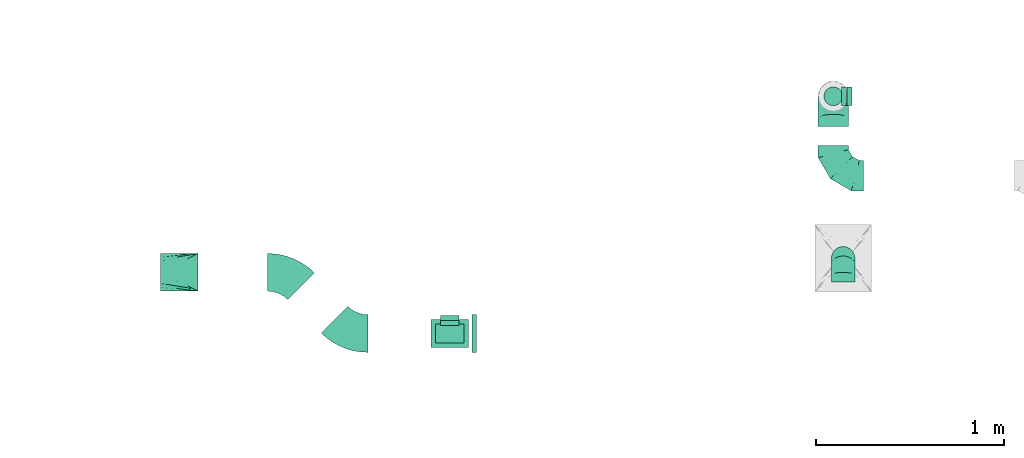
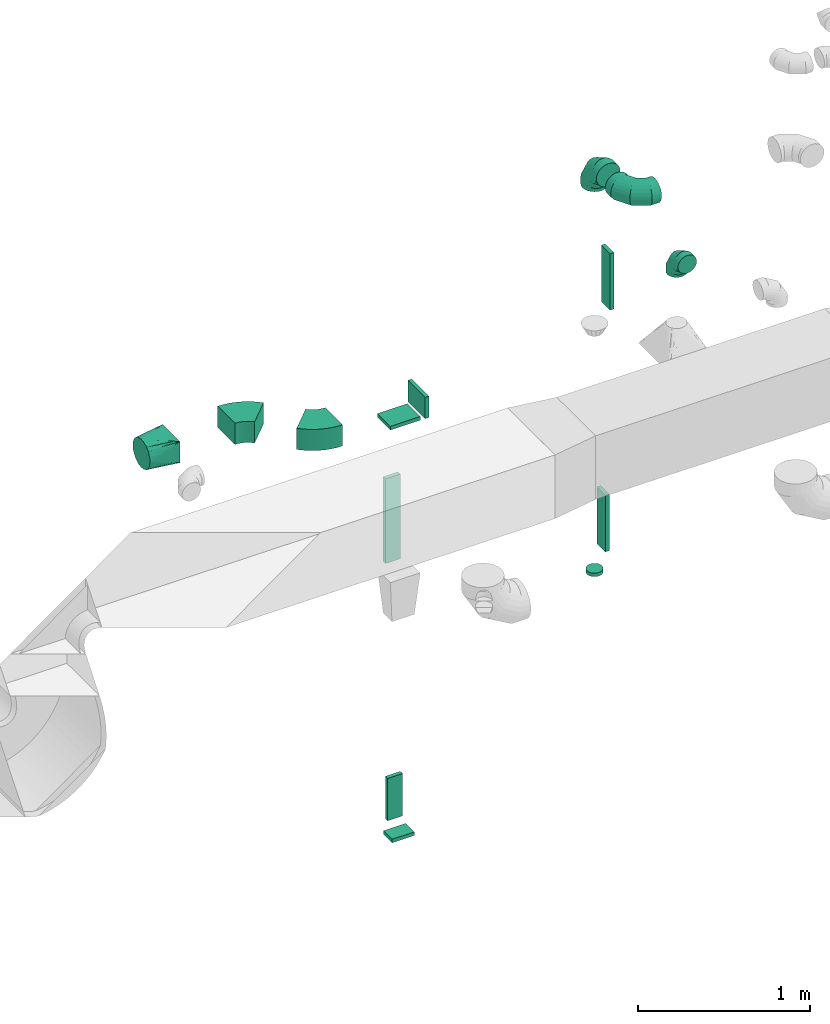
# One storey, part 78 of 97: 14 flow fittings.
"""IFC2X3 building model written with IfcOpenShell, lengths in millimetres."""

import ifcopenshell
import ifcopenshell.guid

model = None  # the IFC model being written
_history = None  # IfcOwnerHistory: only IFC2X3 demands one
_inside = {}  # id of a spatial element -> (the spatial element, [elements in it])
_under = {}  # id of a project, library or spatial element -> (it, [spatial elements below it])
_declared = {}  # id of a project -> (the project, [libraries it declares])
_typed = {}  # id of a type object -> (the type object, [elements of that type])
_made_of = {}  # id of a material, layer set ... -> (it, [elements and type objects made of it])


def new_model(schema):
    """Start an empty IFC model of exactly this schema.

    Asked for "IFC4X3", IfcOpenShell would pick the latest addendum, in which some entities
    have other attributes; the version numbers below select the first issue.
    IFC2X3 requires an IfcOwnerHistory on every rooted entity: one is made here for all.
    """
    global model, _history
    if schema == "IFC4X3":
        model = ifcopenshell.file(schema_version=(4, 3, 0, 0))
    else:
        model = ifcopenshell.file(schema=schema)
    _inside.clear()
    _under.clear()
    _declared.clear()
    _typed.clear()
    _made_of.clear()
    _history = None
    if model.schema == "IFC2X3":
        org = make("IfcOrganization", Name="unknown")
        user = make(
            "IfcPersonAndOrganization",
            ThePerson=make("IfcPerson", FamilyName="unknown"),
            TheOrganization=org,
        )
        app = make(
            "IfcApplication",
            ApplicationDeveloper=org,
            Version="unknown",
            ApplicationFullName="unknown",
            ApplicationIdentifier="unknown",
        )
        _history = make(
            "IfcOwnerHistory",
            OwningUser=user,
            OwningApplication=app,
            ChangeAction="ADDED",
            CreationDate=0,
        )
    return model


def make(cls, **values):
    """One entity of the class cls with the attributes given. An attribute that is None is left unset."""
    return model.create_entity(
        cls, **{name: value for name, value in values.items() if value is not None}
    )


def entity(cls, *values):
    """Any entity or typed value of the class cls, its attributes in the order of the schema. None: left unset."""
    e = model.create_entity(cls)
    for i, value in enumerate(values):
        if value is not None:
            e[i] = value
    return e


def rooted(cls, **values):
    """An entity with a GlobalId (a new one), such as an element, a storey or a relation."""
    return make(cls, GlobalId=ifcopenshell.guid.new(), OwnerHistory=_history, **values)


def si_unit(unit_type, name, prefix=None):
    """IfcSIUnit, for example si_unit("LENGTHUNIT", "METRE", prefix="MILLI")."""
    return make("IfcSIUnit", UnitType=unit_type, Prefix=prefix, Name=name)


def converted_unit(unit_type, name, factor, base, dimensions=None, offset=None):
    """IfcConversionBasedUnit, such as the inch: factor (a typed value) times the base unit."""
    return make(
        "IfcConversionBasedUnit"
        if offset is None
        else "IfcConversionBasedUnitWithOffset",
        ConversionOffset=offset,
        Dimensions=None
        if dimensions is None
        else entity("IfcDimensionalExponents", *dimensions),
        UnitType=unit_type,
        Name=name,
        ConversionFactor=make(
            "IfcMeasureWithUnit", ValueComponent=factor, UnitComponent=base
        ),
    )


def derived_unit(unit_type, elements):
    """IfcDerivedUnit: a product of units, each with its exponent."""
    return make(
        "IfcDerivedUnit",
        Elements=[
            make("IfcDerivedUnitElement", Unit=unit, Exponent=power)
            for unit, power in elements
        ],
        UnitType=unit_type,
    )


def assignment(units):
    """IfcUnitAssignment: the units of a project."""
    return None if units is None else make("IfcUnitAssignment", Units=units)


def point(xyz):
    """IfcCartesianPoint."""
    return None if xyz is None else make("IfcCartesianPoint", Coordinates=xyz)


def direction(xyz):
    """IfcDirection."""
    return None if xyz is None else make("IfcDirection", DirectionRatios=xyz)


def frame(location, z_axis=None, x_axis=None):
    """IfcAxis2Placement3D, a coordinate frame: its origin and axes. An axis left out is left unset."""
    return make(
        "IfcAxis2Placement3D",
        Location=point(location),
        Axis=direction(z_axis),
        RefDirection=direction(x_axis),
    )


def frame_2d(location, x_axis=None):
    """IfcAxis2Placement2D, a coordinate frame in the plane: its origin and x axis."""
    return make(
        "IfcAxis2Placement2D", Location=point(location), RefDirection=direction(x_axis)
    )


def origin():
    """The frame at (0, 0, 0) with its axes left unset."""
    return frame((0.0, 0.0, 0.0))


def origin_2d_with_axis():
    """The frame at (0, 0) in the plane with the x axis (1, 0) written out."""
    return frame_2d((0.0, 0.0), x_axis=(1.0, 0.0))


def place(relative_to, where):
    """IfcLocalPlacement: puts the frame where relative to a parent placement (None: the world)."""
    return make(
        "IfcLocalPlacement", PlacementRelTo=relative_to, RelativePlacement=where
    )


def context(
    kind, dimensions, precision=None, world=None, true_north=None, identifier=None
):
    """IfcGeometricRepresentationContext, for example the 3D "Model" context."""
    return make(
        "IfcGeometricRepresentationContext",
        ContextIdentifier=identifier,
        ContextType=kind,
        CoordinateSpaceDimension=dimensions,
        Precision=precision,
        WorldCoordinateSystem=world,
        TrueNorth=true_north,
    )


def subcontext(parent, identifier, kind, view, scale=None):
    """IfcGeometricRepresentationSubContext, for example "Body" below "Model"."""
    return make(
        "IfcGeometricRepresentationSubContext",
        ContextIdentifier=identifier,
        ContextType=kind,
        ParentContext=parent,
        TargetScale=scale,
        TargetView=view,
    )


def project(units=None, contexts=None):
    """IfcProject with its units and contexts."""
    return rooted(
        "IfcProject",
        Name="project",
        RepresentationContexts=contexts,
        UnitsInContext=assignment(units),
    )


def spatial(cls, under=None, at=None, **own):
    """A site, building, storey or space (cls), placed at a placement, below another one or the project."""
    s = rooted(cls, ObjectPlacement=at, **own)
    if under is not None:
        _under.setdefault(under.id(), (under, []))[1].append(s)
    return s


def polyline(points):
    """IfcPolyline through the points."""
    return make("IfcPolyline", Points=[point(p) for p in points])


def circle_curve(where, radius):
    """IfcCircle in the frame where."""
    return make("IfcCircle", Position=where, Radius=radius)


def parameter(value):
    """IfcParameterValue: where a trimmed curve begins or ends, as a parameter of its basis curve."""
    return model.create_entity("IfcParameterValue", value)


def trimmed(basis, trim1, trim2, sense, master):
    """IfcTrimmedCurve: the piece of a basis curve between two trims."""
    return make(
        "IfcTrimmedCurve",
        BasisCurve=basis,
        Trim1=trim1,
        Trim2=trim2,
        SenseAgreement=sense,
        MasterRepresentation=master,
    )


def segment(curve, same_sense, transition):
    """IfcCompositeCurveSegment."""
    return make(
        "IfcCompositeCurveSegment",
        Transition=transition,
        SameSense=same_sense,
        ParentCurve=curve,
    )


def composite_curve(segments, self_intersect=None):
    """IfcCompositeCurve: segments joined end to end."""
    return make("IfcCompositeCurve", Segments=segments, SelfIntersect=self_intersect)


def profile(cls, at=None, kind="AREA", **sizes):
    """A parametric profile (cls). Its sizes go by their IFC names, for example OverallWidth=200.0."""
    return make(cls, ProfileType=kind, Position=at, **sizes)


def rectangle(**sizes):
    """IfcRectangleProfileDef."""
    return profile("IfcRectangleProfileDef", **sizes)


def circle(**sizes):
    """IfcCircleProfileDef."""
    return profile("IfcCircleProfileDef", **sizes)


def outline(outer, holes=None, kind="AREA"):
    """IfcArbitraryClosedProfileDef: a profile drawn as a closed curve; with holes, ...WithVoids."""
    if holes is None:
        return make("IfcArbitraryClosedProfileDef", ProfileType=kind, OuterCurve=outer)
    return make(
        "IfcArbitraryProfileDefWithVoids",
        ProfileType=kind,
        OuterCurve=outer,
        InnerCurves=holes,
    )


def extrude(swept, where, along, depth):
    """IfcExtrudedAreaSolid: the profile swept, set in the frame where, extruded along a direction by depth."""
    return make(
        "IfcExtrudedAreaSolid",
        SweptArea=swept,
        Position=where,
        ExtrudedDirection=direction(along),
        Depth=depth,
    )


def faces_of(points, faces, orient=None, outer=None):
    """IfcFace entities. A face is a list of loops; a loop is a list of indices into points, from 0.

    orient and outer hold one flag for each loop. By default every Orientation is true, the
    first loop of a face is its IfcFaceOuterBound and the others are IfcFaceBound.
    """
    made = []
    for i, loops in enumerate(faces):
        bounds = []
        for j, loop in enumerate(loops):
            is_outer = j == 0 if outer is None else outer[i][j]
            bounds.append(
                make(
                    "IfcFaceOuterBound" if is_outer else "IfcFaceBound",
                    Bound=make("IfcPolyLoop", Polygon=[points[k] for k in loop]),
                    Orientation=True if orient is None else orient[i][j],
                )
            )
        made.append(make("IfcFace", Bounds=bounds))
    return made


def faceted_brep(points, faces, orient=None, outer=None, voids=None):
    """IfcFacetedBrep: a solid bounded by flat faces; with voids (closed shells), ...WithVoids."""
    shared = [point(p) for p in points]
    hull = make("IfcClosedShell", CfsFaces=faces_of(shared, faces, orient, outer))
    if voids is None:
        return make("IfcFacetedBrep", Outer=hull)
    return make(
        "IfcFacetedBrepWithVoids",
        Outer=hull,
        Voids=[
            make(cls, CfsFaces=faces_of(shared, fs, o, b)) for cls, fs, o, b in voids
        ],
    )


def shape(context_of_items, identifier, shape_type, items):
    """IfcShapeRepresentation: the items that make up one representation, for example the "Body"."""
    return make(
        "IfcShapeRepresentation",
        ContextOfItems=context_of_items,
        RepresentationIdentifier=identifier,
        RepresentationType=shape_type,
        Items=items,
    )


def source(mapping_origin, context_of_items, identifier, shape_type, items):
    """IfcRepresentationMap: a shape defined once, which mapped items show again and again."""
    return make(
        "IfcRepresentationMap",
        MappingOrigin=mapping_origin,
        MappedRepresentation=shape(context_of_items, identifier, shape_type, items),
    )


def transform(
    local_origin,
    x_axis=None,
    y_axis=None,
    z_axis=None,
    scale=None,
    scale2=None,
    scale3=None,
    uniform=True,
):
    """IfcCartesianTransformationOperator3D, or its non-uniform kind. x_axis, y_axis, z_axis: its Axis1, 2, 3."""
    if uniform:
        return make(
            "IfcCartesianTransformationOperator3D",
            Axis1=direction(x_axis),
            Axis2=direction(y_axis),
            LocalOrigin=point(local_origin),
            Scale=scale,
            Axis3=direction(z_axis),
        )
    return make(
        "IfcCartesianTransformationOperator3DnonUniform",
        Axis1=direction(x_axis),
        Axis2=direction(y_axis),
        LocalOrigin=point(local_origin),
        Scale=scale,
        Axis3=direction(z_axis),
        Scale2=scale2,
        Scale3=scale3,
    )


def mapped(mapping_source, mapping_target):
    """IfcMappedItem: shows the shape of a source again, moved by a transform."""
    return make(
        "IfcMappedItem", MappingSource=mapping_source, MappingTarget=mapping_target
    )


def material(Name=None, Category=None):
    """IfcMaterial."""
    return make("IfcMaterial", Name=Name, Category=Category)


def made_of(thing, what):
    """Note that an element or type object is made of a material, layer set ...; save() writes the relation."""
    if what is not None:
        _made_of.setdefault(what.id(), (what, []))[1].append(thing)
    return thing


def type_object(cls, material=None, **own):
    """A type object (cls), such as IfcWallType, which elements share."""
    return made_of(rooted(cls, **own), material)


def type_shapes(of_type, sources):
    """Give a type object the sources (RepresentationMaps) that its elements show as mapped items."""
    of_type.RepresentationMaps = sources


def element(
    cls,
    number,
    at=None,
    inside=None,
    cuts=None,
    type_object=None,
    material=None,
    context=None,
    identifier="Body",
    shape_type=None,
    held_by="IfcProductDefinitionShape",
    body=None,
    shapes=None,
    **own,
):
    """One element of the class cls, such as IfcWall. Its Tag is "e" and its number.

    at: its placement. inside: the storey or other place that contains it. cuts: it is an
    opening in that element (IfcRelVoidsElement). A single representation is given by context,
    identifier, shape_type and body (its items); several are given by shapes. held_by: the class
    of the entity that holds the representations. save() writes the other relations.
    """
    e = rooted(cls, Tag="e%d" % number, ObjectPlacement=at, **own)
    if body is not None:
        shapes = [shape(context, identifier, shape_type, body)]
    if shapes is not None:
        e.Representation = make(held_by, Representations=shapes)
    if inside is not None:
        _inside.setdefault(inside.id(), (inside, []))[1].append(e)
    if cuts is not None:
        rooted(
            "IfcRelVoidsElement", RelatingBuildingElement=cuts, RelatedOpeningElement=e
        )
    if type_object is not None:
        _typed.setdefault(type_object.id(), (type_object, []))[1].append(e)
    return made_of(e, material)


def aggregate(whole, parts):
    """IfcRelAggregates: a whole, such as a stair, and the parts it consists of."""
    return rooted("IfcRelAggregates", RelatingObject=whole, RelatedObjects=parts)


def save(model, path):
    """Write the relations noted so far, then the file.

    IfcRelAggregates (storeys below a building ...), IfcRelContainedInSpatialStructure (elements
    in a storey), IfcRelDefinesByType, IfcRelAssociatesMaterial and IfcRelDeclares: one each for
    every whole, place, type object, material and project.
    """
    for whole, parts in _under.values():
        aggregate(whole, parts)
    for where, things in _inside.values():
        rooted(
            "IfcRelContainedInSpatialStructure",
            RelatedElements=things,
            RelatingStructure=where,
        )
    for kind, things in _typed.values():
        rooted("IfcRelDefinesByType", RelatedObjects=things, RelatingType=kind)
    for what, things in _made_of.values():
        rooted("IfcRelAssociatesMaterial", RelatedObjects=things, RelatingMaterial=what)
    for by, libraries in _declared.values():
        rooted("IfcRelDeclares", RelatingContext=by, RelatedDefinitions=libraries)
    model.write(path)


model = new_model("IFC2X3")

# Units and contexts
model_context = context("Model", 3, precision=0.01, world=origin(), true_north=direction((6.12303176911189e-17, 1.0)))
body_context = subcontext(model_context, "Body", "Model", "MODEL_VIEW")
ifc_project = project(units=[si_unit("LENGTHUNIT", "METRE", prefix="MILLI"), si_unit("AREAUNIT", "SQUARE_METRE"), si_unit("VOLUMEUNIT", "CUBIC_METRE"), converted_unit("PLANEANGLEUNIT", "DEGREE", entity("IfcRatioMeasure", 0.0174532925199433), si_unit("PLANEANGLEUNIT", "RADIAN"), dimensions=[0, 0, 0, 0, 0, 0, 0]), si_unit("MASSUNIT", "GRAM", prefix="KILO"), derived_unit("MASSDENSITYUNIT", [(si_unit("MASSUNIT", "GRAM", prefix="KILO"), 1), (si_unit("LENGTHUNIT", "METRE"), -3)]), derived_unit("MOMENTOFINERTIAUNIT", [(si_unit("LENGTHUNIT", "METRE"), 4)]), si_unit("TIMEUNIT", "SECOND"), si_unit("FREQUENCYUNIT", "HERTZ"), si_unit("THERMODYNAMICTEMPERATUREUNIT", "DEGREE_CELSIUS"), derived_unit("THERMALTRANSMITTANCEUNIT", [(si_unit("MASSUNIT", "GRAM", prefix="KILO"), 1), (si_unit("THERMODYNAMICTEMPERATUREUNIT", "KELVIN"), -1), (si_unit("TIMEUNIT", "SECOND"), -3)]), derived_unit("VOLUMETRICFLOWRATEUNIT", [(si_unit("LENGTHUNIT", "METRE"), 3), (si_unit("TIMEUNIT", "SECOND"), -1)]), derived_unit("MASSFLOWRATEUNIT", [(si_unit("MASSUNIT", "GRAM", prefix="KILO"), 1), (si_unit("TIMEUNIT", "SECOND"), -1)]), derived_unit("ROTATIONALFREQUENCYUNIT", [(si_unit("TIMEUNIT", "SECOND"), -1)]), si_unit("ELECTRICCURRENTUNIT", "AMPERE"), si_unit("ELECTRICVOLTAGEUNIT", "VOLT"), si_unit("POWERUNIT", "WATT"), si_unit("FORCEUNIT", "NEWTON", prefix="KILO"), si_unit("ILLUMINANCEUNIT", "LUX"), si_unit("LUMINOUSFLUXUNIT", "LUMEN"), si_unit("LUMINOUSINTENSITYUNIT", "CANDELA"), derived_unit("USERDEFINED", [(si_unit("MASSUNIT", "GRAM", prefix="KILO"), -1), (si_unit("LENGTHUNIT", "METRE"), -2), (si_unit("TIMEUNIT", "SECOND"), 3), (si_unit("LUMINOUSFLUXUNIT", "LUMEN"), 1)]), derived_unit("LINEARVELOCITYUNIT", [(si_unit("LENGTHUNIT", "METRE"), 1), (si_unit("TIMEUNIT", "SECOND"), -1)]), si_unit("PRESSUREUNIT", "PASCAL"), derived_unit("USERDEFINED", [(si_unit("LENGTHUNIT", "METRE"), -2), (si_unit("MASSUNIT", "GRAM", prefix="KILO"), 1), (si_unit("TIMEUNIT", "SECOND"), -2)]), derived_unit("LINEARFORCEUNIT", [(si_unit("MASSUNIT", "GRAM", prefix="KILO"), 1), (si_unit("LENGTHUNIT", "METRE"), 1), (si_unit("TIMEUNIT", "SECOND"), -2), (si_unit("LENGTHUNIT", "METRE"), -1)]), derived_unit("PLANARFORCEUNIT", [(si_unit("MASSUNIT", "GRAM", prefix="KILO"), 1), (si_unit("LENGTHUNIT", "METRE"), 1), (si_unit("TIMEUNIT", "SECOND"), -2), (si_unit("LENGTHUNIT", "METRE"), -2)])], contexts=[model_context])

# Site, building, storey
site_placement = place(None, origin())
site = spatial("IfcSite", under=ifc_project, at=site_placement, CompositionType="ELEMENT")
building_placement = place(site_placement, origin())
building = spatial("IfcBuilding", under=site, at=building_placement, CompositionType="ELEMENT")
storey_placement = place(building_placement, frame((0.0, 0.0, -4900.0)))
storey = spatial("IfcBuildingStorey", under=building, at=storey_placement, CompositionType="ELEMENT", Elevation=-4900.0)

# Flow fittings
ifc_material = material()
duct_fitting_type_1 = type_object("IfcDuctFittingType", PredefinedType="NOTDEFINED", material=ifc_material)
shared_shape_1 = source(origin(), body_context, "Body", "SweptSolid", [
    extrude(rectangle(XDim=26.0960000001476, YDim=300.0, at=origin_2d_with_axis()), frame((6.95, 0.0, -50.0)), (0.0, 0.0, 1.0), 100.0),
])
type_shapes(duct_fitting_type_1, [shared_shape_1])
flow_fitting_1_placement = place(storey_placement, frame((53026.91, 16598.87, 1000.0), z_axis=(1.0, 0.0, 0.0), x_axis=(0.0, 1.0, 0.0)))
element("IfcFlowFitting", 1, at=flow_fitting_1_placement, inside=storey, type_object=duct_fitting_type_1, material=ifc_material, context=body_context, shape_type="MappedRepresentation", body=[
    mapped(shared_shape_1, transform((0.0, 0.0, 0.0), scale=1.0)),
])
duct_fitting_type_2 = type_object("IfcDuctFittingType", PredefinedType="NOTDEFINED", material=ifc_material)
shared_shape_2 = source(origin(), body_context, "Body", "SweptSolid", [
    extrude(circle(Radius=49.9999999999997, at=origin_2d_with_axis()), frame((0.0, 0.0, 0.0), z_axis=(1.0, 0.0, 0.0), x_axis=(0.0, 1.0, 0.0)), (0.0, 0.0, 1.0), 25.0000000000018),
])
type_shapes(duct_fitting_type_2, [shared_shape_2])
flow_fitting_2_placement = place(storey_placement, frame((55064.27, 17808.79, 1170.0), z_axis=(-1.0, 0.0, 0.0), x_axis=(0.0, 0.0, -1.0)))
element("IfcFlowFitting", 2, at=flow_fitting_2_placement, inside=storey, type_object=duct_fitting_type_2, material=ifc_material, context=body_context, shape_type="MappedRepresentation", body=[
    mapped(shared_shape_2, transform((0.0, 0.0, 0.0), scale=1.0)),
])
duct_fitting_type_3 = type_object("IfcDuctFittingType", PredefinedType="NOTDEFINED", material=ifc_material)
shared_shape_3 = source(origin(), body_context, "Body", "SweptSolid", [
    extrude(rectangle(XDim=26.0960000000009, YDim=600.0, at=origin_2d_with_axis()), frame((6.95, 0.0, -50.0)), (0.0, 0.0, 1.0), 100.0),
])
type_shapes(duct_fitting_type_3, [shared_shape_3])
flow_fitting_3_placement = place(storey_placement, frame((53026.91, 16623.87, 2955.0), z_axis=(1.0, 0.0, 0.0), x_axis=(0.0, 1.0, 0.0)))
element("IfcFlowFitting", 3, at=flow_fitting_3_placement, inside=storey, type_object=duct_fitting_type_3, material=ifc_material, context=body_context, shape_type="MappedRepresentation", body=[
    mapped(shared_shape_3, transform((0.0, 0.0, 0.0), scale=1.0)),
])
duct_fitting_type_4 = type_object("IfcDuctFittingType", PredefinedType="NOTDEFINED", material=ifc_material)
shared_shape_4 = source(origin(), body_context, "Body", "SweptSolid", [
    extrude(rectangle(XDim=26.0960000000006, YDim=400.0, at=origin_2d_with_axis()), frame((6.95, 0.0, -50.0)), (0.0, 0.0, 1.0), 100.0),
])
type_shapes(duct_fitting_type_4, [shared_shape_4])
for number, where, z_axis, x_axis in (
    (4, (55144.27, 17808.79, 3200.0), (0.0, -1.0, 0.0), (1.0, 0.0, 0.0)),
    (5, (55114.27, 17808.79, 1500.0), (0.0, -1.0, 0.0), (1.0, 0.0, 0.0)),
):
    element("IfcFlowFitting", number, at=place(storey_placement, frame(where, z_axis=z_axis, x_axis=x_axis)), inside=storey, type_object=duct_fitting_type_4, material=ifc_material, context=body_context, shape_type="MappedRepresentation", body=[
        mapped(shared_shape_4, transform((0.0, 0.0, 0.0), scale=1.0)),
    ])
duct_fitting_type_5 = type_object("IfcDuctFittingType", PredefinedType="NOTDEFINED", material=ifc_material)
shared_shape_5 = source(origin(), body_context, "Body", "SweptSolid", [
    extrude(rectangle(XDim=24.9999999999999, YDim=200.0, at=origin_2d_with_axis()), frame((12.5, 0.0, -75.0)), (0.0, 0.0, 1.0), 150.0),
])
type_shapes(duct_fitting_type_5, [shared_shape_5])
flow_fitting_4_placement = place(storey_placement, frame((53145.16, 16548.87, 3800.0)))
element("IfcFlowFitting", 6, at=flow_fitting_4_placement, inside=storey, type_object=duct_fitting_type_5, material=ifc_material, context=body_context, shape_type="MappedRepresentation", body=[
    mapped(shared_shape_5, transform((0.0, 0.0, 0.0), scale=1.0)),
])
duct_fitting_type_6 = type_object("IfcDuctFittingType", PredefinedType="NOTDEFINED", material=ifc_material)
shared_shape_6 = source(origin(), body_context, "Body", "SweptSolid", [
    extrude(rectangle(XDim=150.0, YDim=26.0960333077056, at=origin_2d_with_axis()), frame((6.95, 0.0, -100.0), z_axis=(0.0, 0.0, 1.0), x_axis=(0.0, -1.0, 0.0)), (0.0, 0.0, 1.0), 200.0),
])
type_shapes(duct_fitting_type_6, [shared_shape_6])
flow_fitting_5_placement = place(storey_placement, frame((53026.91, 16548.87, 3725.0), z_axis=(-1.0, 0.0, 0.0), x_axis=(0.0, 0.0, -1.0)))
element("IfcFlowFitting", 7, at=flow_fitting_5_placement, inside=storey, type_object=duct_fitting_type_6, material=ifc_material, context=body_context, shape_type="MappedRepresentation", body=[
    mapped(shared_shape_6, transform((0.0, 0.0, 0.0), scale=1.0)),
])
duct_fitting_type_7 = type_object("IfcDuctFittingType", PredefinedType="NOTDEFINED", material=ifc_material)
shared_shape_7 = source(origin(), body_context, "Body", "SweptSolid", [
    extrude(rectangle(XDim=24.9999999999999, YDim=100.0, at=origin_2d_with_axis()), frame((12.5, 0.0, -75.0)), (0.0, 0.0, 1.0), 150.0),
])
type_shapes(duct_fitting_type_7, [shared_shape_7])
flow_fitting_6_placement = place(storey_placement, frame((53026.91, 16548.87, 785.0), z_axis=(-1.0, 0.0, 0.0), x_axis=(0.0, 0.0, -1.0)))
element("IfcFlowFitting", 8, at=flow_fitting_6_placement, inside=storey, type_object=duct_fitting_type_7, material=ifc_material, context=body_context, shape_type="MappedRepresentation", body=[
    mapped(shared_shape_7, transform((0.0, 0.0, 0.0), scale=1.0)),
])
duct_fitting_type_8 = type_object("IfcDuctFittingType", PredefinedType="NOTDEFINED", material=ifc_material)
shared_shape_8 = source(origin(), body_context, "Body", "Brep", [
    faceted_brep([(-160.0, 0.0, -80.0), (-160.0, -20.71, -77.27), (-160.0, -40.0, -69.28), (-160.0, -56.57, -56.57), (-160.0, -69.28, -40.0), (-160.0, -77.27, -20.71), (-160.0, -80.0, 0.0), (-160.0, -77.27, 20.71), (-160.0, -69.28, 40.0), (-160.0, -56.57, 56.57), (-160.0, -40.0, 69.28), (-160.0, -20.71, 77.27), (-160.0, 0.0, 80.0), (-160.0, 20.71, 77.27), (-160.0, 40.0, 69.28), (-160.0, 56.57, 56.57), (-160.0, 69.28, 40.0), (-160.0, 77.27, 20.71), (-160.0, 80.0, 0.0), (-160.0, 77.27, -20.71), (-160.0, 69.28, -40.0), (-160.0, 56.57, -56.57), (-160.0, 40.0, -69.28), (-160.0, 20.71, -77.27), (-122.68, 20.71, 77.27), (-127.85, 40.0, 69.28), (-117.13, 0.0, 80.0), (-132.29, 56.57, 56.57), (-137.83, 77.27, 20.71), (-138.56, 80.0, 0.0), (-135.69, 69.28, 40.0), (-135.69, 69.28, -40.0), (-132.29, 56.57, -56.57), (-137.83, 77.27, -20.71), (-122.68, 20.71, -77.27), (-117.13, 0.0, -80.0), (-127.85, 40.0, -69.28), (-111.58, -20.71, -77.27), (-106.41, -40.0, -69.28), (-101.97, -56.57, -56.57), (-98.56, -69.28, -40.0), (-96.42, -77.27, -20.71), (-95.69, -80.0, 0.0), (-96.42, -77.27, 20.71), (-98.56, -69.28, 40.0), (-101.97, -56.57, 56.57), (-106.41, -40.0, 69.28), (-111.58, -20.71, 77.27), (-58.03, 58.03, 77.27), (-72.15, 72.15, 69.28), (-42.87, 42.87, 80.0), (-84.28, 84.28, 56.57), (-93.59, 93.59, 40.0), (-99.44, 99.44, 20.71), (-101.44, 101.44, 0.0), (-99.44, 99.44, -20.71), (-93.59, 93.59, -40.0), (-84.28, 84.28, -56.57), (-58.03, 58.03, -77.27), (-42.87, 42.87, -80.0), (-72.15, 72.15, -69.28), (-27.71, 27.71, -77.27), (-13.59, 13.59, -69.28), (-1.46, 1.46, -56.57), (7.85, -7.85, -40.0), (13.7, -13.7, -20.71), (15.69, -15.69, 0.0), (13.7, -13.7, 20.71), (7.85, -7.85, 40.0), (-1.46, 1.46, 56.57), (-13.59, 13.59, 69.28), (-27.71, 27.71, 77.27), (-20.71, 122.68, 77.27), (-40.0, 127.85, 69.28), (0.0, 117.13, 80.0), (-56.57, 132.29, 56.57), (-69.28, 135.69, 40.0), (-77.27, 137.83, 20.71), (-80.0, 138.56, 0.0), (-77.27, 137.83, -20.71), (-69.28, 135.69, -40.0), (-56.57, 132.29, -56.57), (-20.71, 122.68, -77.27), (0.0, 117.13, -80.0), (-40.0, 127.85, -69.28), (20.71, 111.58, -77.27), (40.0, 106.41, -69.28), (56.57, 101.97, -56.57), (69.28, 98.56, -40.0), (77.27, 96.42, -20.71), (80.0, 95.69, 0.0), (77.27, 96.42, 20.71), (69.28, 98.56, 40.0), (56.57, 101.97, 56.57), (40.0, 106.41, 69.28), (20.71, 111.58, 77.27), (-20.71, 160.0, -77.27), (-40.0, 160.0, -69.28), (-56.57, 160.0, -56.57), (-69.28, 160.0, -40.0), (-77.27, 160.0, -20.71), (-80.0, 160.0, 0.0), (-77.27, 160.0, 20.71), (-69.28, 160.0, 40.0), (-56.57, 160.0, 56.57), (-40.0, 160.0, 69.28), (-20.71, 160.0, 77.27), (0.0, 160.0, 80.0), (20.71, 160.0, 77.27), (40.0, 160.0, 69.28), (56.57, 160.0, 56.57), (69.28, 160.0, 40.0), (77.27, 160.0, 20.71), (80.0, 160.0, 0.0), (77.27, 160.0, -20.71), (69.28, 160.0, -40.0), (56.57, 160.0, -56.57), (40.0, 160.0, -69.28), (20.71, 160.0, -77.27), (0.0, 160.0, -80.0)], [[[0, 1, 2, 3, 4, 5, 6, 7, 8, 9, 10, 11, 12, 13, 14, 15, 16, 17, 18, 19, 20, 21, 22, 23]], [[24, 25, 14, 13]], [[26, 24, 13, 12]], [[14, 25, 27, 15]], [[28, 29, 18, 17]], [[30, 28, 17, 16]], [[15, 27, 30, 16]], [[20, 31, 32, 21]], [[33, 31, 20, 19]], [[18, 29, 33, 19]], [[34, 35, 0, 23]], [[36, 34, 23, 22]], [[32, 36, 22, 21]], [[1, 0, 35, 37]], [[2, 1, 37, 38]], [[3, 2, 38, 39]], [[5, 4, 40, 41]], [[6, 5, 41, 42]], [[39, 40, 4, 3]], [[6, 42, 43, 7]], [[7, 43, 44, 8]], [[8, 44, 45, 9]], [[9, 45, 46, 10]], [[10, 46, 47, 11]], [[26, 12, 11, 47]], [[48, 49, 25, 24]], [[50, 48, 24, 26]], [[27, 25, 49, 51]], [[52, 53, 28, 30]], [[51, 52, 30, 27]], [[29, 28, 53, 54]], [[55, 56, 31, 33]], [[54, 55, 33, 29]], [[32, 31, 56, 57]], [[58, 59, 35, 34]], [[60, 58, 34, 36]], [[57, 60, 36, 32]], [[37, 35, 59, 61]], [[38, 37, 61, 62]], [[39, 38, 62, 63]], [[41, 40, 64, 65]], [[42, 41, 65, 66]], [[63, 64, 40, 39]], [[43, 42, 66, 67]], [[44, 43, 67, 68]], [[68, 69, 45, 44]], [[46, 45, 69, 70]], [[47, 46, 70, 71]], [[26, 47, 71, 50]], [[72, 73, 49, 48]], [[74, 72, 48, 50]], [[51, 49, 73, 75]], [[76, 77, 53, 52]], [[75, 76, 52, 51]], [[54, 53, 77, 78]], [[79, 80, 56, 55]], [[78, 79, 55, 54]], [[57, 56, 80, 81]], [[82, 83, 59, 58]], [[84, 82, 58, 60]], [[81, 84, 60, 57]], [[61, 59, 83, 85]], [[62, 61, 85, 86]], [[63, 62, 86, 87]], [[65, 64, 88, 89]], [[66, 65, 89, 90]], [[87, 88, 64, 63]], [[67, 66, 90, 91]], [[68, 67, 91, 92]], [[92, 93, 69, 68]], [[70, 69, 93, 94]], [[71, 70, 94, 95]], [[50, 71, 95, 74]], [[96, 97, 98, 99, 100, 101, 102, 103, 104, 105, 106, 107, 108, 109, 110, 111, 112, 113, 114, 115, 116, 117, 118, 119]], [[72, 74, 107, 106]], [[73, 72, 106, 105]], [[75, 73, 105, 104]], [[77, 76, 103, 102]], [[78, 77, 102, 101]], [[75, 104, 103, 76]], [[78, 101, 100, 79]], [[79, 100, 99, 80]], [[80, 99, 98, 81]], [[84, 97, 96, 82]], [[82, 96, 119, 83]], [[84, 81, 98, 97]], [[118, 117, 86, 85]], [[119, 118, 85, 83]], [[116, 87, 86, 117]], [[88, 115, 114, 89]], [[89, 114, 113, 90]], [[115, 88, 87, 116]], [[112, 111, 92, 91]], [[113, 112, 91, 90]], [[111, 110, 93, 92]], [[95, 94, 109, 108]], [[74, 95, 108, 107]], [[110, 109, 94, 93]]]),
])
type_shapes(duct_fitting_type_8, [shared_shape_8])
for number, where, z_axis, x_axis in (
    (9, (55064.27, 17387.0, 4050.0), (0.0, 0.0, 1.0), (0.0, -1.0, 0.0)),
    (10, (55064.27, 17808.79, 4050.0), (-1.0, 0.0, 0.0), (0.0, 1.0, 0.0)),
):
    element("IfcFlowFitting", number, at=place(storey_placement, frame(where, z_axis=z_axis, x_axis=x_axis)), inside=storey, type_object=duct_fitting_type_8, material=ifc_material, context=body_context, shape_type="MappedRepresentation", body=[
        mapped(shared_shape_8, transform((0.0, 0.0, 0.0), scale=1.0)),
    ])
duct_fitting_type_9 = type_object("IfcDuctFittingType", PredefinedType="NOTDEFINED", material=ifc_material)
shared_shape_9 = source(origin(), body_context, "Body", "Brep", [
    faceted_brep([(-125.0, 0.0, -62.5), (-125.0, -16.18, -60.37), (-125.0, -31.25, -54.13), (-125.0, -44.19, -44.19), (-125.0, -54.13, -31.25), (-125.0, -60.37, -16.18), (-125.0, -62.5, 0.0), (-125.0, -60.37, 16.18), (-125.0, -54.13, 31.25), (-125.0, -44.19, 44.19), (-125.0, -31.25, 54.13), (-125.0, -16.18, 60.37), (-125.0, 0.0, 62.5), (-125.0, 16.18, 60.37), (-125.0, 31.25, 54.13), (-125.0, 44.19, 44.19), (-125.0, 54.13, 31.25), (-125.0, 60.37, 16.18), (-125.0, 62.5, 0.0), (-125.0, 60.37, -16.18), (-125.0, 54.13, -31.25), (-125.0, 44.19, -44.19), (-125.0, 31.25, -54.13), (-125.0, 16.18, -60.37), (-95.84, 16.18, 60.37), (-99.88, 31.25, 54.13), (-91.51, 0.0, 62.5), (-103.35, 44.19, 44.19), (-107.68, 60.37, 16.18), (-108.25, 62.5, 0.0), (-106.01, 54.13, 31.25), (-106.01, 54.13, -31.25), (-103.35, 44.19, -44.19), (-107.68, 60.37, -16.18), (-95.84, 16.18, -60.37), (-91.51, 0.0, -62.5), (-99.88, 31.25, -54.13), (-87.17, -16.18, -60.37), (-83.13, -31.25, -54.13), (-79.66, -44.19, -44.19), (-77.0, -54.13, -31.25), (-75.33, -60.37, -16.18), (-74.76, -62.5, 0.0), (-75.33, -60.37, 16.18), (-77.0, -54.13, 31.25), (-79.66, -44.19, 44.19), (-83.13, -31.25, 54.13), (-87.17, -16.18, 60.37), (-45.34, 45.34, 60.37), (-56.37, 56.37, 54.13), (-33.49, 33.49, 62.5), (-65.85, 65.85, 44.19), (-73.12, 73.12, 31.25), (-77.69, 77.69, 16.18), (-79.25, 79.25, 0.0), (-77.69, 77.69, -16.18), (-73.12, 73.12, -31.25), (-65.85, 65.85, -44.19), (-45.34, 45.34, -60.37), (-33.49, 33.49, -62.5), (-56.37, 56.37, -54.13), (-21.65, 21.65, -60.37), (-10.62, 10.62, -54.13), (-1.14, 1.14, -44.19), (6.13, -6.13, -31.25), (10.7, -10.7, -16.18), (12.26, -12.26, 0.0), (10.7, -10.7, 16.18), (6.13, -6.13, 31.25), (-1.14, 1.14, 44.19), (-10.62, 10.62, 54.13), (-21.65, 21.65, 60.37), (-16.18, 95.84, 60.37), (-31.25, 99.88, 54.13), (0.0, 91.51, 62.5), (-44.19, 103.35, 44.19), (-54.13, 106.01, 31.25), (-60.37, 107.68, 16.18), (-62.5, 108.25, 0.0), (-60.37, 107.68, -16.18), (-54.13, 106.01, -31.25), (-44.19, 103.35, -44.19), (-16.18, 95.84, -60.37), (0.0, 91.51, -62.5), (-31.25, 99.88, -54.13), (16.18, 87.17, -60.37), (31.25, 83.13, -54.13), (44.19, 79.66, -44.19), (54.13, 77.0, -31.25), (60.37, 75.33, -16.18), (62.5, 74.76, 0.0), (60.37, 75.33, 16.18), (54.13, 77.0, 31.25), (44.19, 79.66, 44.19), (31.25, 83.13, 54.13), (16.18, 87.17, 60.37), (-16.18, 125.0, -60.37), (-31.25, 125.0, -54.13), (-44.19, 125.0, -44.19), (-54.13, 125.0, -31.25), (-60.37, 125.0, -16.18), (-62.5, 125.0, 0.0), (-60.37, 125.0, 16.18), (-54.13, 125.0, 31.25), (-44.19, 125.0, 44.19), (-31.25, 125.0, 54.13), (-16.18, 125.0, 60.37), (0.0, 125.0, 62.5), (16.18, 125.0, 60.37), (31.25, 125.0, 54.13), (44.19, 125.0, 44.19), (54.13, 125.0, 31.25), (60.37, 125.0, 16.18), (62.5, 125.0, 0.0), (60.37, 125.0, -16.18), (54.13, 125.0, -31.25), (44.19, 125.0, -44.19), (31.25, 125.0, -54.13), (16.18, 125.0, -60.37), (0.0, 125.0, -62.5)], [[[0, 1, 2, 3, 4, 5, 6, 7, 8, 9, 10, 11, 12, 13, 14, 15, 16, 17, 18, 19, 20, 21, 22, 23]], [[24, 25, 14, 13]], [[26, 24, 13, 12]], [[14, 25, 27, 15]], [[28, 29, 18, 17]], [[30, 28, 17, 16]], [[15, 27, 30, 16]], [[20, 31, 32, 21]], [[33, 31, 20, 19]], [[18, 29, 33, 19]], [[34, 35, 0, 23]], [[36, 34, 23, 22]], [[21, 32, 36, 22]], [[1, 0, 35, 37]], [[2, 1, 37, 38]], [[38, 39, 3, 2]], [[5, 4, 40, 41]], [[6, 5, 41, 42]], [[39, 40, 4, 3]], [[6, 42, 43, 7]], [[7, 43, 44, 8]], [[45, 9, 8, 44]], [[9, 45, 46, 10]], [[10, 46, 47, 11]], [[26, 12, 11, 47]], [[48, 49, 25, 24]], [[50, 48, 24, 26]], [[27, 25, 49, 51]], [[52, 53, 28, 30]], [[51, 52, 30, 27]], [[29, 28, 53, 54]], [[55, 56, 31, 33]], [[54, 55, 33, 29]], [[57, 32, 31, 56]], [[58, 59, 35, 34]], [[60, 58, 34, 36]], [[57, 60, 36, 32]], [[37, 35, 59, 61]], [[38, 37, 61, 62]], [[39, 38, 62, 63]], [[41, 40, 64, 65]], [[42, 41, 65, 66]], [[63, 64, 40, 39]], [[43, 42, 66, 67]], [[44, 43, 67, 68]], [[68, 69, 45, 44]], [[46, 45, 69, 70]], [[47, 46, 70, 71]], [[26, 47, 71, 50]], [[72, 73, 49, 48]], [[74, 72, 48, 50]], [[51, 49, 73, 75]], [[76, 77, 53, 52]], [[75, 76, 52, 51]], [[54, 53, 77, 78]], [[79, 80, 56, 55]], [[78, 79, 55, 54]], [[81, 57, 56, 80]], [[82, 83, 59, 58]], [[84, 82, 58, 60]], [[81, 84, 60, 57]], [[61, 59, 83, 85]], [[62, 61, 85, 86]], [[63, 62, 86, 87]], [[65, 64, 88, 89]], [[66, 65, 89, 90]], [[87, 88, 64, 63]], [[67, 66, 90, 91]], [[68, 67, 91, 92]], [[92, 93, 69, 68]], [[70, 69, 93, 94]], [[71, 70, 94, 95]], [[50, 71, 95, 74]], [[96, 97, 98, 99, 100, 101, 102, 103, 104, 105, 106, 107, 108, 109, 110, 111, 112, 113, 114, 115, 116, 117, 118, 119]], [[72, 74, 107, 106]], [[73, 72, 106, 105]], [[75, 73, 105, 104]], [[77, 76, 103, 102]], [[78, 77, 102, 101]], [[75, 104, 103, 76]], [[78, 101, 100, 79]], [[79, 100, 99, 80]], [[80, 99, 98, 81]], [[96, 119, 83, 82]], [[97, 96, 82, 84]], [[84, 81, 98, 97]], [[83, 119, 118, 85]], [[85, 118, 117, 86]], [[116, 87, 86, 117]], [[88, 115, 114, 89]], [[89, 114, 113, 90]], [[115, 88, 87, 116]], [[91, 90, 113, 112]], [[92, 91, 112, 111]], [[111, 110, 93, 92]], [[95, 94, 109, 108]], [[74, 95, 108, 107]], [[110, 109, 94, 93]]]),
])
type_shapes(duct_fitting_type_9, [shared_shape_9])
flow_fitting_7_placement = place(storey_placement, frame((55116.59, 16948.43, 3900.0), z_axis=(-1.0, 0.0, 0.0), x_axis=(0.0, 1.0, 0.0)))
element("IfcFlowFitting", 11, at=flow_fitting_7_placement, inside=storey, type_object=duct_fitting_type_9, material=ifc_material, context=body_context, shape_type="MappedRepresentation", body=[
    mapped(shared_shape_9, transform((0.0, 0.0, 0.0), scale=1.0)),
])
duct_fitting_type_10 = type_object("IfcDuctFittingType", PredefinedType="NOTDEFINED", material=ifc_material)
shared_shape_10 = source(origin(), body_context, "Body", "Brep", [
    faceted_brep([(200.0, 30.9, 95.11), (200.0, 19.08, 96.98), (200.0, 9.54, 98.49), (200.0, 4.77, 99.24), (200.0, 0.0, 100.0), (200.0, -4.77, 99.24), (200.0, -9.54, 98.49), (200.0, -19.08, 96.98), (200.0, -30.9, 95.11), (200.0, -44.84, 88.0), (200.0, -58.78, 80.9), (200.0, -69.84, 69.84), (200.0, -80.9, 58.78), (200.0, -88.0, 44.84), (200.0, -95.11, 30.9), (200.0, -96.98, 19.08), (200.0, -98.49, 9.54), (200.0, -99.24, 4.77), (200.0, -100.0, 0.0), (200.0, -99.24, -4.77), (200.0, -98.49, -9.54), (200.0, -96.98, -19.08), (200.0, -95.11, -30.9), (200.0, -88.0, -44.84), (200.0, -80.9, -58.78), (200.0, -69.84, -69.84), (200.0, -58.78, -80.9), (200.0, -44.84, -88.0), (200.0, -30.9, -95.11), (200.0, -19.08, -96.98), (200.0, -9.54, -98.49), (200.0, -4.77, -99.24), (200.0, 0.0, -100.0), (200.0, 4.77, -99.24), (200.0, 9.54, -98.49), (200.0, 19.08, -96.98), (200.0, 30.9, -95.11), (200.0, 44.84, -88.0), (200.0, 58.78, -80.9), (200.0, 69.84, -69.84), (200.0, 80.9, -58.78), (200.0, 88.0, -44.84), (200.0, 95.11, -30.9), (200.0, 96.98, -19.08), (200.0, 98.49, -9.54), (200.0, 99.24, -4.77), (200.0, 100.0, 0.0), (200.0, 99.24, 4.77), (200.0, 98.49, 9.54), (200.0, 96.98, 19.08), (200.0, 95.11, 30.9), (200.0, 88.0, 44.84), (200.0, 80.9, 58.78), (200.0, 69.84, 69.84), (200.0, 58.78, 80.9), (200.0, 44.84, 88.0), (0.0, -100.0, 75.0), (0.0, 100.0, 75.0), (0.0, 100.0, -75.0), (0.0, -100.0, -75.0), (104.11, -47.94, 88.01), (100.0, -83.15, 74.93), (26.03, -86.99, 78.25), (78.09, -60.96, 84.76), (52.06, -73.97, 81.51), (188.01, -5.99, 98.5), (176.03, -11.99, 97.0), (152.06, -23.97, 94.01), (128.09, -35.96, 91.01), (52.06, -100.0, 55.48), (78.09, -100.0, 45.72), (104.11, -100.0, 35.96), (128.09, -100.0, 26.97), (152.06, -100.0, 17.98), (176.03, -100.0, 8.99), (188.01, -100.0, 4.49), (26.03, -100.0, 65.24), (26.03, -100.0, -65.24), (52.06, -100.0, -55.48), (78.09, -100.0, -45.72), (104.11, -100.0, -35.96), (128.09, -100.0, -26.97), (152.06, -100.0, -17.98), (176.03, -100.0, -8.99), (188.01, -100.0, -4.49), (100.0, -87.43, -70.65), (52.06, -73.97, -81.51), (78.09, -60.96, -84.76), (104.11, -47.94, -88.01), (128.09, -35.96, -91.01), (152.06, -23.97, -94.01), (176.03, -11.99, -97.0), (188.01, -5.99, -98.5), (26.03, -86.99, -78.25), (26.03, 86.99, -78.25), (52.06, 73.97, -81.51), (78.09, 60.96, -84.76), (104.11, 47.94, -88.01), (128.09, 35.96, -91.01), (152.06, 23.97, -94.01), (176.03, 11.99, -97.0), (188.01, 5.99, -98.5), (100.0, 83.15, -74.93), (52.06, 100.0, -55.48), (78.09, 100.0, -45.72), (104.11, 100.0, -35.96), (128.09, 100.0, -26.97), (152.06, 100.0, -17.98), (176.03, 100.0, -8.99), (188.01, 100.0, -4.49), (26.03, 100.0, -65.24), (26.03, 100.0, 65.24), (52.06, 100.0, 55.48), (78.09, 100.0, 45.72), (104.11, 100.0, 35.96), (128.09, 100.0, 26.97), (152.06, 100.0, 17.98), (176.03, 100.0, 8.99), (188.01, 100.0, 4.49), (100.0, 87.43, 70.65), (52.06, 73.97, 81.51), (78.09, 60.96, 84.76), (104.11, 47.94, 88.01), (128.09, 35.96, 91.01), (152.06, 23.97, 94.01), (176.03, 11.99, 97.0), (188.01, 5.99, 98.5), (26.03, 86.99, 78.25)], [[[0, 1, 2, 3, 4, 5, 6, 7, 8, 9, 10, 11, 12, 13, 14, 15, 16, 17, 18, 19, 20, 21, 22, 23, 24, 25, 26, 27, 28, 29, 30, 31, 32, 33, 34, 35, 36, 37, 38, 39, 40, 41, 42, 43, 44, 45, 46, 47, 48, 49, 50, 51, 52, 53, 54, 55]], [[56, 57, 58, 59]], [[60, 9, 8]], [[56, 61, 62]], [[9, 60, 63, 64]], [[65, 66, 67, 68, 60, 8, 7, 6, 5, 4]], [[62, 61, 10]], [[13, 69, 70, 71]], [[64, 10, 9]], [[14, 71, 72, 73, 74, 75, 18, 17, 16, 15]], [[12, 76, 69]], [[71, 14, 13]], [[61, 76, 11]], [[10, 64, 62]], [[76, 12, 11]], [[10, 61, 11]], [[61, 56, 76]], [[69, 13, 12]], [[75, 74, 73, 72, 71, 70, 69, 76, 56, 59, 77, 78, 79, 80, 81, 82, 83, 84, 18]], [[80, 23, 22]], [[59, 85, 77]], [[23, 80, 79, 78]], [[84, 83, 82, 81, 80, 22, 21, 20, 19, 18]], [[77, 85, 24]], [[27, 86, 87, 88]], [[78, 24, 23]], [[28, 88, 89, 90, 91, 92, 32, 31, 30, 29]], [[26, 93, 86]], [[88, 28, 27]], [[85, 93, 25]], [[24, 78, 77]], [[93, 26, 25]], [[24, 85, 25]], [[85, 59, 93]], [[86, 27, 26]], [[92, 91, 90, 89, 88, 87, 86, 93, 59, 58, 94, 95, 96, 97, 98, 99, 100, 101, 32]], [[97, 37, 36]], [[58, 102, 94]], [[37, 97, 96, 95]], [[101, 100, 99, 98, 97, 36, 35, 34, 33, 32]], [[94, 102, 38]], [[41, 103, 104, 105]], [[95, 38, 37]], [[42, 105, 106, 107, 108, 109, 46, 45, 44, 43]], [[40, 110, 103]], [[105, 42, 41]], [[102, 110, 39]], [[38, 95, 94]], [[110, 40, 39]], [[38, 102, 39]], [[102, 58, 110]], [[103, 41, 40]], [[58, 57, 111, 112, 113, 114, 115, 116, 117, 118, 46, 109, 108, 107, 106, 105, 104, 103, 110]], [[114, 51, 50]], [[57, 119, 111]], [[51, 114, 113, 112]], [[118, 117, 116, 115, 114, 50, 49, 48, 47, 46]], [[111, 119, 52]], [[55, 120, 121, 122]], [[112, 52, 51]], [[0, 122, 123, 124, 125, 126, 4, 3, 2, 1]], [[54, 127, 120]], [[122, 0, 55]], [[119, 127, 53]], [[52, 112, 111]], [[127, 54, 53]], [[52, 119, 53]], [[119, 57, 127]], [[120, 55, 54]], [[57, 56, 62, 64, 63, 60, 68, 67, 66, 65, 4, 126, 125, 124, 123, 122, 121, 120, 127]]]),
])
type_shapes(duct_fitting_type_10, [shared_shape_10])
flow_fitting_8_placement = place(storey_placement, frame((51691.08, 16873.88, 3800.0), z_axis=(0.0, 0.0, 1.0), x_axis=(-1.0, 0.0, 0.0)))
element("IfcFlowFitting", 12, at=flow_fitting_8_placement, inside=storey, type_object=duct_fitting_type_10, material=ifc_material, context=body_context, shape_type="MappedRepresentation", body=[
    mapped(shared_shape_10, transform((0.0, 0.0, 0.0), scale=1.0)),
])
duct_fitting_type_11 = type_object("IfcDuctFittingType", PredefinedType="NOTDEFINED", material=ifc_material)
shared_shape_11 = source(origin(), body_context, "Body", "SweptSolid", [
    extrude(outline(composite_curve([segment(polyline([(-136.61, -88.39), (63.39, -88.39)]), True, "CONTINUOUS"), segment(trimmed(circle_curve(frame_2d((213.39, -88.39), x_axis=(-0.707106781186546, 0.707106781186546)), 150.0), [parameter(0.0)], [parameter(45.0)], True, "PARAMETER"), False, "CONTINUOUS"), segment(polyline([(107.32, 17.68), (-34.1, 159.1)]), True, "CONTINUOUS"), segment(trimmed(circle_curve(frame_2d((213.39, -88.39), x_axis=(-0.707106781186546, 0.707106781186546)), 350.0), [parameter(0.0)], [parameter(45.0)], True, "PARAMETER"), True, "CONTINUOUS")], self_intersect=False)), frame((-15.17, 36.61, -75.0), z_axis=(0.0, 0.0, 1.0), x_axis=(-0.707106781186547, 0.707106781186548, 0.0)), (0.0, 0.0, 1.0), 150.0),
])
type_shapes(duct_fitting_type_11, [shared_shape_11])
for number, where, z_axis, x_axis in (
    (13, (52163.43, 16873.88, 3800.0), (0.0, 0.0, 1.0), (-0.707106781186529, 0.707106781186566, 0.0)),
    (14, (52488.44, 16548.87, 3800.0), (0.0, 0.0, 1.0), (0.70710678118646, -0.707106781186635, 0.0)),
):
    element("IfcFlowFitting", number, at=place(storey_placement, frame(where, z_axis=z_axis, x_axis=x_axis)), inside=storey, type_object=duct_fitting_type_11, material=ifc_material, context=body_context, shape_type="MappedRepresentation", body=[
        mapped(shared_shape_11, transform((0.0, 0.0, 0.0), scale=1.0)),
    ])

save(model, "model.ifc")
